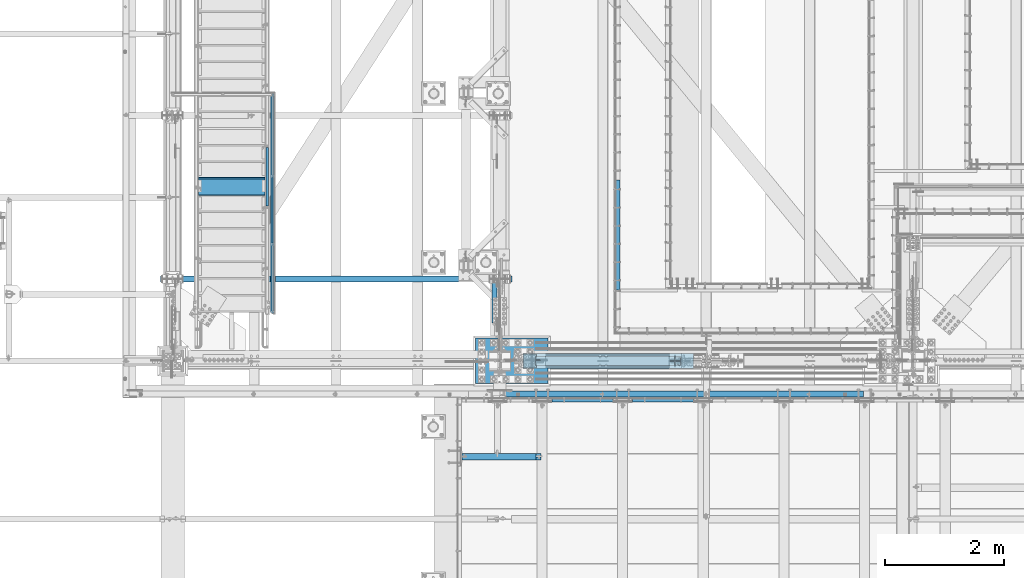
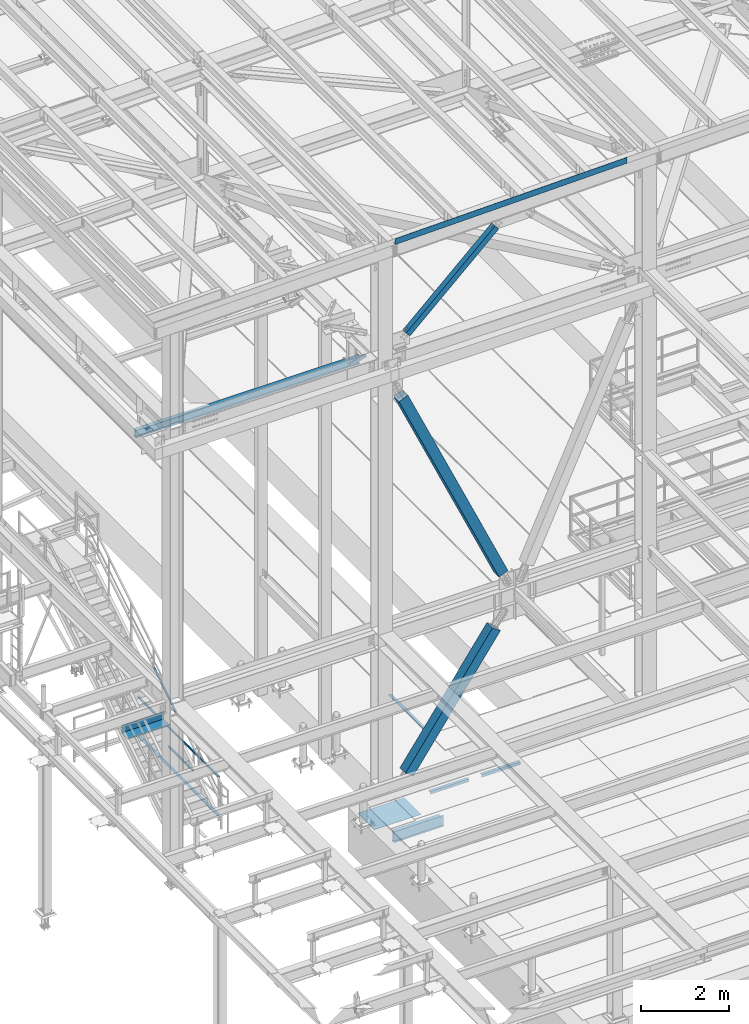
# One storey, part 1745 of 3843: 11 beams, 5 members, 15 elements without a shape of their own.
"""IFC2X3 building model written with IfcOpenShell, lengths in millimetres."""

from ifc_helpers import new_model, si_unit, frame, origin_with_axes, place, context, subcontext, project, spatial, faceted_brep, material, type_object, element, aggregate, save


model = new_model("IFC2X3")

# Units and contexts
model_context = context("Model", 3, precision=1e-05, world=origin_with_axes())
body_context = subcontext(model_context, "Body", "Model", "MODEL_VIEW")
ifc_project = project(units=[si_unit("LENGTHUNIT", "METRE", prefix="MILLI"), si_unit("AREAUNIT", "SQUARE_METRE"), si_unit("VOLUMEUNIT", "CUBIC_METRE"), si_unit("MASSUNIT", "GRAM", prefix="KILO"), si_unit("TIMEUNIT", "SECOND"), si_unit("PLANEANGLEUNIT", "RADIAN"), si_unit("SOLIDANGLEUNIT", "STERADIAN"), si_unit("THERMODYNAMICTEMPERATUREUNIT", "DEGREE_CELSIUS"), si_unit("LUMINOUSINTENSITYUNIT", "LUMEN")], contexts=[model_context])

# Site, building, storey
site_placement = place(None, origin_with_axes())
site = spatial("IfcSite", under=ifc_project, at=site_placement, CompositionType="ELEMENT")
building_placement = place(site_placement, origin_with_axes())
building = spatial("IfcBuilding", under=site, at=building_placement, Name="Undefined", CompositionType="ELEMENT")
storey_placement = place(building_placement, origin_with_axes())
storey = spatial("IfcBuildingStorey", under=building, at=storey_placement, Name="Undefined", CompositionType="ELEMENT", Elevation=0.0)

# Assembly, beam
assembly_1_placement = place(storey_placement, origin_with_axes())
assembly_1 = element("IfcElementAssembly", 1, at=assembly_1_placement, inside=storey, Name="EMBED_ANGLE", AssemblyPlace="NOTDEFINED", PredefinedType="RIGID_FRAME")
ifc_material_1 = material(Name="STEEL/A36")
beam_type_1 = type_object("IfcBeamType", Name="L3-1/2X3-1/2X5/16", PredefinedType="NOTDEFINED")
beam_1_placement = place(assembly_1_placement, frame((44036.996014527, 26803.350515381, 30419.675), z_axis=(0.0, 0.0, -1.0), x_axis=(0.0, 1.0, 0.0)))
beam_1 = element("IfcBeam", 2, at=beam_1_placement, type_object=beam_type_1, material=ifc_material_1, Name="EMBED_ANGLE", ObjectType="L3-1/2X3-1/2X5/16", context=body_context, shape_type="Brep", body=[
    faceted_brep([(-3.63797880709171e-12, 44.4499999999971, -44.4500000000007), (-3.63797880709171e-12, 44.4499999999971, 44.4500000000007), (1851.02448425323, 44.4499999934196, 44.4500000000007), (1851.02448425323, 44.4499999934196, -44.4500000000007), (-3.63797880709171e-12, 36.5124999999971, 44.4500000000007), (1851.02448425323, 36.5124999934196, 44.4500000000007), (-3.63797880709171e-12, 36.5124999999971, -36.5125000000007), (1851.02448425323, 36.5124999934196, -36.5125000000007), (3.63797880709171e-12, -44.4499999999971, -36.5125000000007), (1851.02448425324, -44.4500000065746, -36.5125000000007), (3.63797880709171e-12, -44.4499999999971, -44.4500000000007), (1851.02448425324, -44.4500000065746, -44.4500000000007)], [[[0, 1, 2, 3]], [[1, 4, 5, 2]], [[4, 6, 7, 5]], [[6, 8, 9, 7]], [[8, 10, 11, 9]], [[10, 0, 3, 11]], [[5, 7, 9, 11, 3, 2]], [[10, 8, 6, 4, 1, 0]]]),
])
aggregate(assembly_1, [beam_1])

# Assembly, beams
assembly_2_placement = place(storey_placement, origin_with_axes())
assembly_2 = element("IfcElementAssembly", 3, at=assembly_2_placement, inside=storey, Name="RAIL", AssemblyPlace="NOTDEFINED", PredefinedType="RIGID_FRAME")
ifc_material_2 = material()
beam_type_2 = type_object("IfcBeamType", Name="HSS1-1/2X1-1/2X1/4", PredefinedType="NOTDEFINED")
beam_2_placement = place(assembly_2_placement, frame((38258.75, 27571.6999999811, 31013.4), z_axis=(0.0, 0.0, 1.0), x_axis=(0.0, 1.0, 0.0)))
beam_2 = element("IfcBeam", 4, at=beam_2_placement, type_object=beam_type_2, material=ifc_material_2, Name="RAIL", ObjectType="HSS1-1/2X1-1/2X1/4", context=body_context, shape_type="Brep", body=[
    faceted_brep([(1123.95, -19.0500000000029, 19.0499992350015), (1123.95, -19.0499992350015, -19.0499992350015), (1123.95, 19.0499992350015, -19.0499992350015), (1123.95, 19.0499992350015, 19.0499992350015), (1123.95, -12.6999993299978, 12.6999993300014), (1123.95, 12.6999993299978, 12.6999993300014), (1123.95, 12.6999993299978, -12.6999993300014), (1123.95, -12.6999993299978, -12.6999993300014), (19.0499992350015, 19.0499992350015, -19.0499992350015), (19.0499992350015, 19.0499992350015, 19.0499992350015), (19.0499992350015, -19.0499992350015, 19.0499992350015), (19.0499992350015, -19.0499992350015, -19.0499992350015), (19.0499992350015, 12.6999993299978, 12.6999993299978), (19.0499992350015, -12.6999993299978, 12.6999993299978), (19.0499992350015, -12.6999993299978, -12.6999993299978), (19.0499992350015, 12.6999993299978, -12.6999993299978)], [[[0, 1, 2, 3], [4, 5, 6, 7]], [[8, 9, 3, 2]], [[9, 10, 0, 3]], [[10, 11, 1, 0]], [[11, 8, 2, 1]], [[11, 10, 9, 8], [12, 13, 14, 15]], [[14, 13, 4, 7]], [[15, 14, 7, 6]], [[12, 15, 6, 5]], [[13, 12, 5, 4]]]),
])
beam_3_placement = place(assembly_2_placement, frame((38258.7500000003, 30105.349999216, 31546.8), z_axis=(0.0, 0.0, -1.0), x_axis=(0.0, -1.0, 0.0)))
beam_3 = element("IfcBeam", 5, at=beam_3_placement, type_object=beam_type_2, material=ifc_material_2, Name="RAIL", ObjectType="HSS1-1/2X1-1/2X1/4", context=body_context, shape_type="Brep", body=[
    faceted_brep([(6.34999999999854, 12.6999993299978, -12.6999993299978), (6.34999999999854, -12.6999993299978, -12.6999993299978), (3689.34999856487, -12.6999993299978, -12.6999993300014), (3689.34999856487, 12.6999993299978, -12.6999993300014), (31.7500007135677, -12.6999993300014, 12.6999993299978), (3663.94999990487, -12.6999993299978, 12.6999993300014), (31.7500007135677, 12.6999993300014, 12.6999993299978), (3663.94999990487, 12.6999993299978, 12.6999993300014), (0.0, 19.0500000000029, -19.0499999999993), (38.0999984699883, 19.0499992350015, 19.0499992350015), (3657.59999999987, 19.0499992350015, 19.0499992350015), (3695.69999846987, 19.0499992350015, -19.0499992350015), (38.0999984699883, -19.0499992350015, 19.0499992350015), (3657.59999999987, -19.0499992350015, 19.0499992350015), (0.0, -19.0499992350015, -19.0499992350015), (3695.69999846987, -19.0499992350015, -19.0499992350015)], [[[0, 1, 2, 3]], [[1, 4, 5, 2]], [[4, 6, 7, 5]], [[6, 0, 3, 7]], [[8, 9, 10, 11]], [[9, 12, 13, 10]], [[12, 14, 15, 13]], [[14, 8, 11, 15]], [[13, 15, 11, 10], [5, 7, 3, 2]], [[14, 12, 9, 8], [6, 4, 1, 0]]]),
])
aggregate(assembly_2, [beam_2, beam_3])

# Assembly, member
assembly_3_placement = place(storey_placement, origin_with_axes())
assembly_3 = element("IfcElementAssembly", 6, at=assembly_3_placement, inside=storey, Name="RAIL", AssemblyPlace="NOTDEFINED", PredefinedType="RIGID_FRAME")
member_type_1 = type_object("IfcMemberType", Name="HSS1-1/2X1-1/2X1/4", PredefinedType="NOTDEFINED")
member_1_placement = place(assembly_3_placement, frame((38163.4999999687, 28194.0, 32288.0181821069), z_axis=(0.0, -0.529007926750979, 0.848616882600523), x_axis=(0.0, 0.848616882600524, 0.529007926750978)))
member_1 = element("IfcMember", 7, at=member_1_placement, type_object=member_type_1, material=ifc_material_2, Name="RAIL", ObjectType="HSS1-1/2X1-1/2X1/4", context=body_context, shape_type="Brep", body=[
    faceted_brep([(1194.15206246817, -19.0499999811145, 19.0499992336445), (1170.40141407416, -19.0499992350015, -19.0499992362566), (1170.40141407416, 19.0499992350015, -19.0499992362566), (1194.15206246817, 19.0499992350015, 19.0499992336445), (1190.19362096973, -12.6999993299978, 12.6999993286627), (1190.19362096973, 12.6999993299978, 12.6999993286627), (1174.35985557328, 12.6999993299978, -12.6999993312675), (1174.35985557328, -12.6999993299978, -12.6999993312675), (10.5729683018217, 19.0499992350015, -19.0499992349742), (34.3236166958304, 19.0499992350015, 19.0499992349305), (34.3236166958304, -19.0500000222455, 19.0499992349305), (10.5729683018217, -19.0499992350015, -19.0499992349742), (30.3651751973375, -12.6999993299978, 12.6999993299451), (14.5314098008821, -12.6999993299978, -12.6999993299924), (14.5314098008821, 12.6999993299978, -12.6999993299924), (30.3651751973375, 12.6999993299978, 12.6999993299451)], [[[0, 1, 2, 3], [4, 5, 6, 7]], [[8, 9, 3, 2]], [[9, 10, 0, 3]], [[10, 11, 1, 0]], [[11, 8, 2, 1]], [[10, 9, 8, 11], [12, 13, 14, 15]], [[13, 12, 4, 7]], [[14, 13, 7, 6]], [[15, 14, 6, 5]], [[12, 15, 5, 4]]]),
])
aggregate(assembly_3, [member_1])

# Assembly, beam
assembly_4_placement = place(storey_placement, origin_with_axes())
assembly_4 = element("IfcElementAssembly", 8, at=assembly_4_placement, inside=storey, Name="ref.", AssemblyPlace="NOTDEFINED", PredefinedType="RIGID_FRAME")
ifc_material_3 = material(Name="STEEL/Steel_Undefined")
beam_type_3 = type_object("IfcBeamType", PredefinedType="NOTDEFINED")
beam_4_placement = place(assembly_4_placement, frame((38258.75, 30086.2999999812, 30476.825), z_axis=(1.0, 0.0, 0.0), x_axis=(0.0, -1.0, 0.0)))
beam_4 = element("IfcBeam", 9, at=beam_4_placement, type_object=beam_type_3, material=ifc_material_3, Name="ref.", context=body_context, shape_type="Brep", body=[
    faceted_brep([(0.0, 3.17500000000291, -38.0999999999985), (0.0, 3.17500000000291, 38.0999999999985), (3657.6, 3.17499999999927, 38.0999999999985), (3657.6, 3.17499999999927, -38.0999999999985), (0.0, -3.17500000000291, 38.0999999999985), (3657.6, -3.17499999999927, 38.0999999999985), (0.0, -3.17500000000291, -38.0999999999985), (3657.6, -3.17499999999927, -38.0999999999985)], [[[0, 1, 2, 3]], [[1, 4, 5, 2]], [[4, 6, 7, 5]], [[6, 0, 3, 7]], [[5, 7, 3, 2]], [[6, 4, 1, 0]]]),
])
aggregate(assembly_4, [beam_4])

assembly_5_placement = place(storey_placement, origin_with_axes())
assembly_5 = element("IfcElementAssembly", 10, at=assembly_5_placement, inside=storey, Name="BEAM", AssemblyPlace="NOTDEFINED", PredefinedType="RIGID_FRAME")
beam_type_4 = type_object("IfcBeamType", PredefinedType="NOTDEFINED")
beam_5_placement = place(assembly_5_placement, frame((45114.5844842388, 25107.8999997356, 45913.4197297843), z_axis=(0.999776270257024, 0.0, 0.0211520550054619), x_axis=(0.0, -1.0, 0.0)))
beam_5 = element("IfcBeam", 11, at=beam_5_placement, type_object=beam_type_4, material=ifc_material_1, Name="BENT_PLATE", context=body_context, shape_type="Brep", body=[
    faceted_brep([(-3.50355549016967e-07, -3.17499999742722, -3048.00000001723), (3.50421032635495e-07, -3.17500000260043, 3048.00000001724), (3.5035191103816e-07, 3.17499999739084, 3048.00000001724), (-3.50424670614302e-07, 3.17500000256405, -3048.00000001723), (101.599999864371, 3.17499999856227, 3048.00000000522), (101.599998739839, 3.17500000373548, -3048.00000002925), (95.249998765099, -3.17499999632128, -3048.00000002851), (95.2499998896274, -3.17500000149448, 3048.00000000597), (101.600000309205, -161.925000875126, 3047.9999999938), (101.599999608374, -161.925000446165, -3048.00000004067), (95.2500003092064, -161.925000900388, 3047.99999999456), (95.2499996083752, -161.925000471427, -3048.00000003992)], [[[0, 1, 2, 3]], [[3, 2, 4, 5]], [[1, 0, 6, 7]], [[5, 4, 8, 9]], [[4, 2, 1, 7, 10, 8]], [[7, 6, 11, 10]], [[6, 0, 3, 5, 9, 11]], [[10, 11, 9, 8]]]),
])
aggregate(assembly_5, [beam_5])

assembly_6_placement = place(storey_placement, origin_with_axes())
assembly_6 = element("IfcElementAssembly", 12, at=assembly_6_placement, inside=storey, Name="ANGLE", AssemblyPlace="NOTDEFINED", PredefinedType="RIGID_FRAME")
beam_type_5 = type_object("IfcBeamType", Name="L3X3X1/4", PredefinedType="NOTDEFINED")
beam_6_placement = place(assembly_6_placement, frame((42935.5242797851, 24961.8499969254, 30365.7000030518), z_axis=(0.0, 0.0, -1.0), x_axis=(1.0, 0.0, 0.0)))
beam_6 = element("IfcBeam", 13, at=beam_6_placement, type_object=beam_type_5, material=ifc_material_1, Name="ANGLE", ObjectType="L3X3X1/4", context=body_context, shape_type="Brep", body=[
    faceted_brep([(0.0, 38.0999999999985, -38.0999999999985), (0.0, 38.0999999999985, 38.0999999999985), (1022.33317453146, 38.1000000000004, 38.0999999999985), (1022.33317453146, 38.1000000000004, -38.0999999999985), (0.0, 31.75, 38.0999999999985), (1022.33317453146, 31.75, 38.0999999999985), (0.0, 31.75, -31.75), (1022.33317453146, 31.75, -31.75), (0.0, -38.0999999999985, -31.75), (1022.33317453146, -38.1000000000004, -31.75), (0.0, -38.0999999999985, -38.0999999999985), (1022.33317453146, -38.1000000000004, -38.0999999999985)], [[[0, 1, 2, 3]], [[1, 4, 5, 2]], [[4, 6, 7, 5]], [[6, 8, 9, 7]], [[8, 10, 11, 9]], [[10, 0, 3, 11]], [[5, 7, 9, 11, 3, 2]], [[10, 8, 6, 4, 1, 0]]]),
])
aggregate(assembly_6, [beam_6])

assembly_7_placement = place(storey_placement, origin_with_axes())
assembly_7 = element("IfcElementAssembly", 14, at=assembly_7_placement, inside=storey, Name="ANGLE", AssemblyPlace="NOTDEFINED", PredefinedType="RIGID_FRAME")
beam_7_placement = place(assembly_7_placement, frame((44288.0742797851, 24961.8499969474, 30365.7000030518), z_axis=(0.0, 0.0, -1.0), x_axis=(1.0, 0.0, 0.0)))
beam_7 = element("IfcBeam", 15, at=beam_7_placement, type_object=beam_type_5, material=ifc_material_1, Name="ANGLE", ObjectType="L3X3X1/4", context=body_context, shape_type="Brep", body=[
    faceted_brep([(0.0, 38.0999999999985, -38.0999999999985), (0.0, 38.0999999999985, 38.0999999999985), (1022.33317453146, 38.1000000000004, 38.0999999999985), (1022.33317453146, 38.1000000000004, -38.0999999999985), (0.0, 31.75, 38.0999999999985), (1022.33317453146, 31.75, 38.0999999999985), (0.0, 31.75, -31.75), (1022.33317453146, 31.75, -31.75), (0.0, -38.0999999999985, -31.75), (1022.33317453146, -38.1000000000004, -31.75), (0.0, -38.0999999999985, -38.0999999999985), (1022.33317453146, -38.1000000000004, -38.0999999999985)], [[[0, 1, 2, 3]], [[1, 4, 5, 2]], [[4, 6, 7, 5]], [[6, 8, 9, 7]], [[8, 10, 11, 9]], [[10, 0, 3, 11]], [[5, 7, 9, 11, 3, 2]], [[10, 8, 6, 4, 1, 0]]]),
])
aggregate(assembly_7, [beam_7])

assembly_8_placement = place(storey_placement, origin_with_axes())
assembly_8 = element("IfcElementAssembly", 16, at=assembly_8_placement, inside=storey, Name="STAIR", AssemblyPlace="NOTDEFINED", PredefinedType="RIGID_FRAME")
ifc_material_4 = material(Name="STEEL/ASTM A1011")
beam_type_6 = type_object("IfcBeamType", PredefinedType="NOTDEFINED")
beam_8_placement = place(assembly_8_placement, frame((37566.5999999524, 28689.2999999812, 32045.9553571485), z_axis=(1.0, 0.0, 0.0), x_axis=(0.0, -1.0, 0.0)))
beam_8 = element("IfcBeam", 17, at=beam_8_placement, type_object=beam_type_6, material=ifc_material_4, Name="TREAD", context=body_context, shape_type="Brep", body=[
    faceted_brep([(0.0, -1.58750000000146, -558.799999999999), (0.0, -1.58750000000146, 558.799999999999), (0.0, 1.58750000000146, 558.799999999999), (0.0, 1.58750000000146, -558.799999999999), (21.7283948539116, 1.58750000000146, 558.800000000003), (21.7283948539116, 1.58750000000146, -558.800000000003), (25.3999999999942, -1.58750000000146, -558.799999999999), (25.3999999999942, -1.58750000000146, 558.799999999999), (-11.0799384794227, 226.55892857143, 558.800000000003), (-11.0799384794227, 226.55892857143, -558.800000000003), (-7.40833333332557, 223.383928571428, -558.800000000003), (-7.40833333332557, 223.383928571428, 558.800000000003), (293.720061520566, 226.55892857143, 558.800000000003), (293.720061520566, 226.55892857143, -558.800000000003), (290.974498041134, 223.383928571428, -558.800000000003), (290.974498041134, 223.383928571428, 558.800000000003), (299.614357882056, 186.140896378427, 558.800000000003), (299.614357882056, 186.140896378427, -558.800000000003), (296.472590667174, 185.682721992918, 558.800000000003), (296.472590667174, 185.682721992918, -558.800000000003)], [[[0, 1, 2, 3]], [[3, 2, 4, 5]], [[1, 0, 6, 7]], [[5, 4, 8, 9]], [[7, 6, 10, 11]], [[9, 8, 12, 13]], [[11, 10, 14, 15]], [[13, 12, 16, 17]], [[12, 8, 4, 2, 1, 7, 11, 15, 18, 16]], [[15, 14, 19, 18]], [[14, 10, 6, 0, 3, 5, 9, 13, 17, 19]], [[18, 19, 17, 16]]]),
])
aggregate(assembly_8, [beam_8])

# Assembly, member
assembly_9_placement = place(storey_placement, origin_with_axes())
assembly_9 = element("IfcElementAssembly", 18, at=assembly_9_placement, inside=storey, Name="ANGLE", AssemblyPlace="NOTDEFINED", PredefinedType="RIGID_FRAME")
ifc_material_5 = material(Name="STEEL/A572-50")
member_type_2 = type_object("IfcMemberType", Name="L3X3X1/4", PredefinedType="NOTDEFINED")
member_2_placement = place(assembly_9_placement, frame((41973.5, 26034.2478294993, 42253.6521705007), z_axis=(0.0, -0.707106781186548, -0.707106781186548), x_axis=(5.70000238222118e-08, 0.707106781186546, -0.707106781186546)))
member_2 = element("IfcMember", 19, at=member_2_placement, type_object=member_type_2, material=ifc_material_5, Name="ANGLE", ObjectType="L3X3X1/4", context=body_context, shape_type="Brep", body=[
    faceted_brep([(1265.10086725769, -38.0999999999985, -31.7499999999272), (1265.10086725772, -38.0999999999985, -38.0999999999112), (1265.10086725772, 38.0999999999985, -38.0999999999112), (1265.10086725733, 38.0999999999985, 38.099999999904), (1265.10086725733, 31.75, 38.099999999904), (1265.10086725769, 31.75, -31.7499999999272), (274.500867262255, 31.75, 38.0999999999112), (274.500867262619, 31.75, -31.7499999999272), (274.500867262619, -38.0999999999985, -31.7499999999272), (274.500867262648, -38.0999999999985, -38.0999999999112), (274.500867262648, 38.0999999999985, -38.0999999999112), (274.500867262255, 38.0999999999985, 38.0999999999112)], [[[0, 1, 2, 3, 4, 5]], [[5, 4, 6, 7]], [[0, 5, 7, 8]], [[1, 0, 8, 9]], [[2, 1, 9, 10]], [[3, 2, 10, 11]], [[4, 3, 11, 6]], [[10, 9, 8, 7, 6, 11]]]),
])
aggregate(assembly_9, [member_2])

# Assembly, beam
assembly_10_placement = place(storey_placement, origin_with_axes())
assembly_10 = element("IfcElementAssembly", 20, at=assembly_10_placement, inside=storey, Name="BEAM", AssemblyPlace="NOTDEFINED", PredefinedType="RIGID_FRAME")
ifc_material_6 = material(Name="STEEL/A992")
beam_type_7 = type_object("IfcBeamType", Name="W8X13", PredefinedType="NOTDEFINED")
beam_9_placement = place(assembly_10_placement, frame((36372.8, 26987.5, 41402.0), z_axis=(0.0, 0.0, 1.0), x_axis=(1.0, 0.0, 0.0)))
beam_9 = element("IfcBeam", 21, at=beam_9_placement, type_object=beam_type_7, material=ifc_material_6, Name="BEAM", ObjectType="W8X13", context=body_context, shape_type="Brep", body=[
    faceted_brep([(0.0, 50.7999999999993, -101.599999999999), (0.0, 50.7999999999993, -95.25), (5892.8, 50.7999999999993, -95.25), (5892.8, 50.7999999999993, -101.599999999999), (0.0, 3.17499999999927, -95.25), (5892.8, 3.17499999999927, -95.25), (-2.44140610448085e-05, 3.17500000000291, 95.2499999999927), (5892.8, 3.17499999999927, 95.25), (0.0, 50.7999999999993, 95.25), (5892.8, 50.7999999999993, 95.25), (0.0, 50.7999999999993, 101.599999999999), (5892.8, 50.7999999999993, 101.599999999999), (0.0, -50.7999999999993, 101.599999999999), (5892.8, -50.7999999999993, 101.599999999999), (0.0, -50.7999999999993, 95.25), (5892.8, -50.7999999999993, 95.25), (0.0, -3.17499999999927, 95.25), (5892.8, -3.17499999999927, 95.25), (0.0, -3.17499999999927, -95.25), (5892.8, -3.17499999999927, -95.25), (0.0, -50.7999999999993, -95.25), (5892.8, -50.7999999999993, -95.25), (0.0, -50.7999999999993, -101.599999999999), (5892.8, -50.7999999999993, -101.599999999999)], [[[0, 1, 2, 3]], [[1, 4, 5, 2]], [[4, 6, 7, 5]], [[6, 8, 9, 7]], [[8, 10, 11, 9]], [[10, 12, 13, 11]], [[12, 14, 15, 13]], [[14, 16, 17, 15]], [[16, 18, 19, 17]], [[18, 20, 21, 19]], [[20, 22, 23, 21]], [[22, 0, 3, 23]], [[5, 7, 9, 11, 13, 15, 17, 19, 21, 23, 3, 2]], [[22, 20, 18, 16, 14, 12, 10, 8, 6, 4, 1, 0]]]),
])
aggregate(assembly_10, [beam_9])

# Assembly, member
assembly_11_placement = place(storey_placement, origin_with_axes())
assembly_11 = element("IfcElementAssembly", 22, at=assembly_11_placement, inside=storey, Name="None", AssemblyPlace="NOTDEFINED", PredefinedType="RIGID_FRAME")
member_type_3 = type_object("IfcMemberType", Name="HSS10X10X1/4", PredefinedType="NOTDEFINED")
member_3_placement = place(assembly_11_placement, frame((42722.4028724657, 25615.9, 30613.0908748764), z_axis=(0.0, -1.0, 0.0), x_axis=(0.577430334981806, 0.0, 0.816439959974278)))
member_3 = element("IfcMember", 23, at=member_3_placement, type_object=member_type_3, material=ifc_material_6, Name="None", ObjectType="HSS10X10X1/4", context=body_context, shape_type="Brep", body=[
    faceted_brep([(2.00088834390044e-10, 120.650000000089, -120.649999999994), (-2.03726813197136e-10, -120.650000000081, -120.649999999994), (3956.04999999908, -120.650000004462, -120.650000000001), (3956.04999999883, 120.64999999624, -120.650000000001), (-2.03726813197136e-10, -120.650000000081, 120.649999999994), (3956.04999999908, -120.650000004462, 120.650000000001), (2.00088834390044e-10, 120.650000000089, 120.649999999994), (3956.04999999883, 120.64999999624, 120.650000000001), (2.16459739021957e-10, 127.000000000087, -127.0), (2.16459739021957e-10, 127.000000000087, 127.0), (3956.04999999882, 126.999999996267, 127.0), (3956.04999999882, 126.999999996267, -127.0), (-2.14640749618411e-10, -127.00000000008, 127.0), (3956.04999999909, -127.000000004475, 127.0), (-2.14640749618411e-10, -127.00000000008, -127.0), (3956.04999999909, -127.000000004475, -127.0)], [[[0, 1, 2, 3]], [[1, 4, 5, 2]], [[4, 6, 7, 5]], [[6, 0, 3, 7]], [[8, 9, 10, 11]], [[9, 12, 13, 10]], [[12, 14, 15, 13]], [[14, 8, 11, 15]], [[13, 15, 11, 10], [5, 7, 3, 2]], [[14, 12, 9, 8], [6, 4, 1, 0]]]),
])
aggregate(assembly_11, [member_3])

assembly_12_placement = place(storey_placement, origin_with_axes())
assembly_12 = element("IfcElementAssembly", 24, at=assembly_12_placement, inside=storey, Name="None", AssemblyPlace="NOTDEFINED", PredefinedType="RIGID_FRAME")
member_4_placement = place(assembly_12_placement, frame((45193.5782091628, 25615.9, 35322.2353792596), z_axis=(0.0, 1.0, 0.0), x_axis=(-0.413289611073596, 0.0, 0.910599636162148)))
member_4 = element("IfcMember", 25, at=member_4_placement, type_object=member_type_3, material=ifc_material_6, Name="None", ObjectType="HSS10X10X1/4", context=body_context, shape_type="Brep", body=[
    faceted_brep([(2.00088834390044e-10, 120.650000000089, -120.649999999994), (-2.03726813197136e-10, -120.650000000081, -120.649999999994), (6356.35072209054, -120.65000000098, -120.650000000001), (6356.35072209057, 120.649999998823, -120.650000000001), (-2.03726813197136e-10, -120.650000000081, 120.649999999994), (6356.35072209054, -120.65000000098, 120.650000000001), (2.00088834390044e-10, 120.650000000089, 120.649999999994), (6356.35072209057, 120.649999998823, 120.650000000001), (2.16459739021957e-10, 127.000000000087, -127.0), (2.16459739021957e-10, 127.000000000087, 127.0), (6356.35072209059, 126.99999999881, 127.0), (6356.35072209059, 126.99999999881, -127.0), (-2.14640749618411e-10, -127.00000000008, 127.0), (6356.35072209054, -127.000000000979, 127.0), (-2.14640749618411e-10, -127.00000000008, -127.0), (6356.35072209054, -127.000000000979, -127.0)], [[[0, 1, 2, 3]], [[1, 4, 5, 2]], [[4, 6, 7, 5]], [[6, 0, 3, 7]], [[8, 9, 10, 11]], [[9, 12, 13, 10]], [[12, 14, 15, 13]], [[14, 8, 11, 15]], [[13, 15, 11, 10], [5, 7, 3, 2]], [[14, 12, 9, 8], [6, 4, 1, 0]]]),
])
aggregate(assembly_12, [member_4])

assembly_13_placement = place(storey_placement, origin_with_axes())
assembly_13 = element("IfcElementAssembly", 26, at=assembly_13_placement, inside=storey, AssemblyPlace="NOTDEFINED", PredefinedType="RIGID_FRAME")
ifc_material_7 = material()
member_type_4 = type_object("IfcMemberType", Name="HSS6X6X3/8", PredefinedType="NOTDEFINED")
member_5_placement = place(assembly_13_placement, frame((42062.4, 25615.8999999454, 42197.3375000034), z_axis=(0.678515287903944, 0.0, -0.734586280896007), x_axis=(0.734586280896006, 0.0, 0.678515287903946)))
member_5 = element("IfcMember", 27, at=member_5_placement, type_object=member_type_4, material=ifc_material_7, ObjectType="HSS6X6X3/8", context=body_context, shape_type="Brep", body=[
    faceted_brep([(4062.45276081734, 7.9375, 76.2000000009575), (3962.44026082085, 7.9375, 76.2000000009284), (3962.44026082085, 7.9375, 66.6750000009561), (4062.45276081734, 7.9375, 66.6750000009743), (3959.40271107647, 7.33329378931012, 76.2000000009284), (3959.40271107647, 7.33329378931012, 66.6750000009451), (3956.82760074522, 5.61266007566883, 76.2000000009248), (3956.82760074522, 5.61266007566883, 66.6750000009451), (3955.10696703159, 3.03754974439653, 76.2000000009211), (3955.10696703159, 3.03754974439653, 66.6750000009488), (3954.50276082091, 0.0, 76.2000000009248), (3954.50276082091, 0.0, 66.6750000009524), (3955.10696703159, -3.03754974439653, 76.2000000009211), (3955.10696703159, -3.03754974439653, 66.6750000009488), (3956.82760074522, -5.61266007566883, 76.2000000009248), (3956.82760074522, -5.61266007566883, 66.6750000009451), (3959.40271107647, -7.33329378931012, 76.2000000009284), (3959.40271107647, -7.33329378931012, 66.6750000009451), (3962.44026082085, -7.9375, 76.2000000009284), (3962.44026082085, -7.9375, 66.6750000009561), (4062.45276081734, -7.9375, 76.2000000009575), (4062.45276081734, -7.9375, 66.6750000009743), (4062.45276081734, 7.9375, -66.674999998675), (3962.44026082088, 7.9375, -66.6749999987078), (3962.44026082089, 7.9375, -76.1999999986801), (4062.45276081735, 7.9375, -76.1999999986474), (3959.4027110765, 7.33329378931012, -66.6749999987078), (3959.40271107652, 7.33329378931012, -76.1999999986801), (3956.82760074526, 5.61266007566883, -66.6749999987042), (3956.82760074527, 5.61266007566883, -76.1999999986838), (3955.10696703164, 3.03754974439653, -66.6749999987005), (3955.10696703164, 3.03754974439653, -76.1999999986801), (3954.50276082094, 0.0, -66.6749999987042), (3954.50276082095, 0.0, -76.1999999986838), (3955.10696703164, -3.03754974439653, -66.6749999987005), (3955.10696703164, -3.03754974439653, -76.1999999986801), (3956.82760074526, -5.61266007566883, -66.6749999987042), (3956.82760074527, -5.61266007566883, -76.1999999986838), (3959.4027110765, -7.33329378931012, -66.6749999987078), (3959.40271107652, -7.33329378931012, -76.1999999986801), (3962.44026082088, -7.9375, -66.6749999987078), (3962.44026082089, -7.9375, -76.1999999986801), (4062.45276081734, -7.9375, -66.674999998675), (4062.45276081735, -7.9375, -76.1999999986474), (887.752478407478, 66.6749999999993, 66.6750000000829), (887.752478407478, 66.6749999999993, -66.67499999957), (4062.45276081734, 66.6749999999993, -66.674999998675), (4062.45276081734, 66.6749999999993, 66.6750000009743), (4062.45276081734, -66.6749999999993, 66.6750000009743), (887.752478407478, -66.6749999999993, 66.6750000000829), (887.752478407478, -20.6375000000007, 66.6750000000829), (987.764978406856, -20.6375000000007, 66.6750000001084), (990.802528151231, -20.0332937893108, 66.6750000001048), (993.377638482481, -18.3126600756696, 66.6750000001048), (995.098272196105, -15.7375497443973, 66.6750000001157), (995.702478406798, -12.7000000000007, 66.6750000001084), (995.098272196105, -9.6624502556042, 66.6750000001157), (993.377638482481, -7.0873399243319, 66.6750000001048), (990.802528151231, -5.36670621069061, 66.6750000001048), (987.764978406856, -4.76250000000073, 66.6750000001084), (887.752478407478, -4.76250000000073, 66.6750000000829), (887.752478407478, -66.6749999999993, -66.67499999957), (4062.45276081734, -66.6749999999993, -66.674999998675), (887.752478407478, -4.76250000000073, -66.67499999957), (987.764978406893, -4.76250000000073, -66.6749999995445), (990.802528151267, -5.36670621069061, -66.6749999995445), (993.377638482518, -7.0873399243319, -66.6749999995409), (995.098272196148, -9.6624502556042, -66.6749999995482), (995.702478406834, -12.7000000000007, -66.6749999995482), (995.098272196148, -15.7375497443973, -66.6749999995482), (993.377638482518, -18.3126600756696, -66.6749999995409), (990.802528151267, -20.0332937893108, -66.6749999995445), (987.764978406893, -20.6375000000007, -66.6749999995445), (887.752478407478, -20.6375000000007, -66.67499999957), (887.752478407478, -4.76250000000073, -76.1999999995533), (987.7649784069, -4.76250000000073, -76.1999999995205), (990.802528151282, -5.36670621069061, -76.1999999995205), (993.377638482525, -7.0873399243319, -76.1999999995205), (995.098272196148, -9.6624502556042, -76.1999999995205), (995.702478406834, -12.7000000000007, -76.1999999995205), (995.098272196148, -15.7375497443973, -76.1999999995205), (993.377638482525, -18.3126600756696, -76.1999999995205), (990.802528151282, -20.0332937893108, -76.1999999995205), (987.7649784069, -20.6375000000007, -76.1999999995205), (887.752478407478, -20.6375000000007, -76.1999999995533), (887.752478407478, -76.2000000000007, -76.1999999995533), (887.752478407478, -76.2000000000007, 76.2000000000553), (887.752478407478, -20.6375000000007, 76.2000000000553), (987.764978406856, -20.6375000000007, 76.2000000000808), (990.802528151224, -20.0332937893108, 76.2000000000844), (993.377638482474, -18.3126600756696, 76.2000000000844), (995.098272196105, -15.7375497443973, 76.2000000000844), (995.702478406791, -12.7000000000007, 76.200000000088), (995.098272196105, -9.6624502556042, 76.2000000000844), (993.377638482474, -7.0873399243319, 76.2000000000844), (990.802528151224, -5.36670621069061, 76.2000000000844), (987.764978406856, -4.76250000000073, 76.2000000000808), (887.752478407478, -4.76250000000073, 76.2000000000553), (887.752478407478, 76.2000000000007, 76.2000000000553), (887.752478407478, 76.2000000000007, -76.1999999995533), (4062.45276081734, 76.2000000000007, 76.2000000009575), (4062.45276081735, 76.2000000000007, -76.1999999986474), (4062.45276081735, -76.2000000000007, -76.1999999986474), (4062.45276081734, -76.2000000000007, 76.2000000009575)], [[[0, 1, 2, 3]], [[4, 5, 2, 1]], [[6, 7, 5, 4]], [[8, 9, 7, 6]], [[10, 11, 9, 8]], [[12, 13, 11, 10]], [[14, 15, 13, 12]], [[16, 17, 15, 14]], [[18, 19, 17, 16]], [[20, 21, 19, 18]], [[22, 23, 24, 25]], [[26, 27, 24, 23]], [[28, 29, 27, 26]], [[30, 31, 29, 28]], [[32, 33, 31, 30]], [[34, 35, 33, 32]], [[36, 37, 35, 34]], [[38, 39, 37, 36]], [[40, 41, 39, 38]], [[42, 43, 41, 40]], [[44, 45, 46, 47]], [[48, 49, 50, 51, 52, 53, 54, 55, 56, 57, 58, 59, 60, 44, 47, 3, 2, 5, 7, 9, 11, 13, 15, 17, 19, 21]], [[61, 49, 48, 62]], [[38, 36, 34, 32, 30, 28, 26, 23, 22, 46, 45, 63, 64, 65, 66, 67, 68, 69, 70, 71, 72, 73, 61, 62, 42, 40]], [[63, 74, 75, 64]], [[64, 75, 76, 65]], [[65, 76, 77, 66]], [[66, 77, 78, 67]], [[67, 78, 79, 68]], [[68, 79, 80, 69]], [[69, 80, 81, 70]], [[70, 81, 82, 71]], [[71, 82, 83, 72]], [[72, 83, 84, 73]], [[49, 61, 73, 84, 85, 86, 87, 50]], [[88, 51, 50, 87]], [[89, 52, 51, 88]], [[90, 53, 52, 89]], [[91, 54, 53, 90]], [[92, 55, 54, 91]], [[93, 56, 55, 92]], [[94, 57, 56, 93]], [[95, 58, 57, 94]], [[96, 59, 58, 95]], [[97, 60, 59, 96]], [[98, 99, 74, 63, 45, 44, 60, 97]], [[99, 98, 100, 101]], [[47, 46, 22, 25, 101, 100, 0, 3]], [[102, 85, 84, 83, 82, 81, 80, 79, 78, 77, 76, 75, 74, 99, 101, 25, 24, 27, 29, 31, 33, 35, 37, 39, 41, 43]], [[86, 85, 102, 103]], [[16, 14, 12, 10, 8, 6, 4, 1, 0, 100, 98, 97, 96, 95, 94, 93, 92, 91, 90, 89, 88, 87, 86, 103, 20, 18]], [[103, 102, 43, 42, 62, 48, 21, 20]]]),
])
aggregate(assembly_13, [member_5])

# Assembly, beam
assembly_14_placement = place(storey_placement, origin_with_axes())
assembly_14 = element("IfcElementAssembly", 28, at=assembly_14_placement, inside=storey, Name="BEAM", AssemblyPlace="NOTDEFINED", PredefinedType="RIGID_FRAME")
beam_type_8 = type_object("IfcBeamType", Name="W12X16", PredefinedType="NOTDEFINED")
beam_10_placement = place(assembly_14_placement, frame((41417.875, 24009.35, 30251.4), z_axis=(0.0, 0.0, 1.0), x_axis=(1.0, 0.0, 0.0)))
beam_10 = element("IfcBeam", 29, at=beam_10_placement, type_object=beam_type_8, material=ifc_material_6, Name="BEAM", ObjectType="W12X16", context=body_context, shape_type="Brep", body=[
    faceted_brep([(1253.33125000001, -50.7999999999993, 152.400000000001), (1253.33125000001, -50.7999999999993, 146.049999999999), (1253.33125000001, -3.17499999999927, 146.049999999999), (1253.33125000001, -3.17499999999927, 139.699999809265), (1253.33125000001, 3.17499999999927, 139.699999809265), (1253.33125000001, 3.17499999999927, 146.049999999999), (1253.33125000001, 50.7999999999993, 146.049999999999), (1253.33125000001, 50.7999999999993, 152.400000000001), (1254.2979799226, -3.17499999999927, 134.839920291219), (1254.2979799226, 3.17499999999927, 134.839920291219), (1257.05099382308, -3.17499999999927, 130.719743823065), (1257.05099382308, 3.17499999999927, 130.719743823065), (1261.17117029123, -3.17499999999927, 127.966729922588), (1261.17117029123, 3.17499999999927, 127.966729922588), (1266.03124980928, -3.17499999999927, 127.0), (1266.03124980928, 3.17499999999927, 127.0), (1335.88125000001, -3.17499999999927, 127.0), (1335.88125000001, 3.17499999999927, 127.0), (12.7000030517593, -50.7999999999993, -152.400000000001), (12.7000030517593, -50.7999999999993, -146.049999999999), (12.7000000064072, -3.17500000016298, -146.049999999763), (12.7000000064072, -3.17499999987194, 146.049999999777), (12.7000030517593, -50.7999999999993, 146.049999999999), (12.7000030517593, -50.7999999999993, 152.400000000001), (12.7000030517593, 50.7999999999993, 152.400000000001), (12.7000030517593, 50.7999999999993, 146.049999999999), (12.7000000064072, 3.17500000014843, 146.04999999977), (12.7000000064072, 3.17499999985739, -146.049999999763), (12.7000030517593, 50.7999999999993, -146.049999999999), (12.7000030517593, 50.7999999999993, -152.400000000001), (1335.88125000001, 3.17499999999927, -146.049999999999), (1335.88125000001, 50.7999999999993, -146.049999999999), (1335.88125000001, 50.7999999999993, -152.400000000001), (1335.88125000001, -50.7999999999993, -152.400000000001), (1335.88125000001, -50.7999999999993, -146.049999999999), (1335.88125000001, -3.17499999999927, -146.049999999999), (1335.88125000001, 3.17499999999927, 114.299999999999), (1335.88125000001, 3.17499999999927, -116.299999999999)], [[[0, 1, 2, 3, 4, 5, 6, 7]], [[8, 9, 4, 3]], [[10, 11, 9, 8]], [[12, 13, 11, 10]], [[14, 15, 13, 12]], [[16, 17, 15, 14]], [[18, 19, 20, 21, 22, 23, 24, 25, 26, 27, 28, 29]], [[28, 27, 30, 31]], [[29, 28, 31, 32]], [[18, 29, 32, 33]], [[19, 18, 33, 34]], [[20, 19, 34, 35]], [[12, 10, 8, 3, 2, 21, 20, 35, 16, 14]], [[22, 21, 2, 1]], [[23, 22, 1, 0]], [[24, 23, 0, 7]], [[25, 24, 7, 6]], [[26, 25, 6, 5]], [[36, 37, 30, 27, 26, 5, 4, 9, 11, 13, 15, 17]], [[35, 34, 33, 32, 31, 30, 37, 36, 17, 16]]]),
])
aggregate(assembly_14, [beam_10])

assembly_15_placement = place(storey_placement, origin_with_axes())
assembly_15 = element("IfcElementAssembly", 30, at=assembly_15_placement, inside=storey, Name="TEMPLATE", AssemblyPlace="NOTDEFINED", PredefinedType="RIGID_FRAME")
beam_type_9 = type_object("IfcBeamType", PredefinedType="NOTDEFINED")
beam_11_placement = place(assembly_15_placement, frame((42265.6, 25234.9000030518, 29608.4625), z_axis=(-1.0, 0.0, 0.0), x_axis=(0.0, 1.0, 0.0)))
beam_11 = element("IfcBeam", 31, at=beam_11_placement, type_object=beam_type_9, material=ifc_material_5, Name="TEMPLATE", context=body_context, shape_type="Brep", body=[
    faceted_brep([(0.0, 4.76250000000073, -609.599999999999), (0.0, 4.76250000000073, 609.599999999999), (762.00001220702, 4.76250000000073, 609.599999999999), (762.00001220702, 4.76250000000073, -609.599999999999), (0.0, -4.76250000000073, 609.599999999999), (762.00001220702, -4.76250000000073, 609.599999999999), (0.0, -4.76250000000073, -609.599999999999), (762.00001220702, -4.76250000000073, -609.599999999999)], [[[0, 1, 2, 3]], [[1, 4, 5, 2]], [[4, 6, 7, 5]], [[6, 0, 3, 7]], [[5, 7, 3, 2]], [[6, 4, 1, 0]]]),
])
aggregate(assembly_15, [beam_11])

save(model, "model.ifc")
